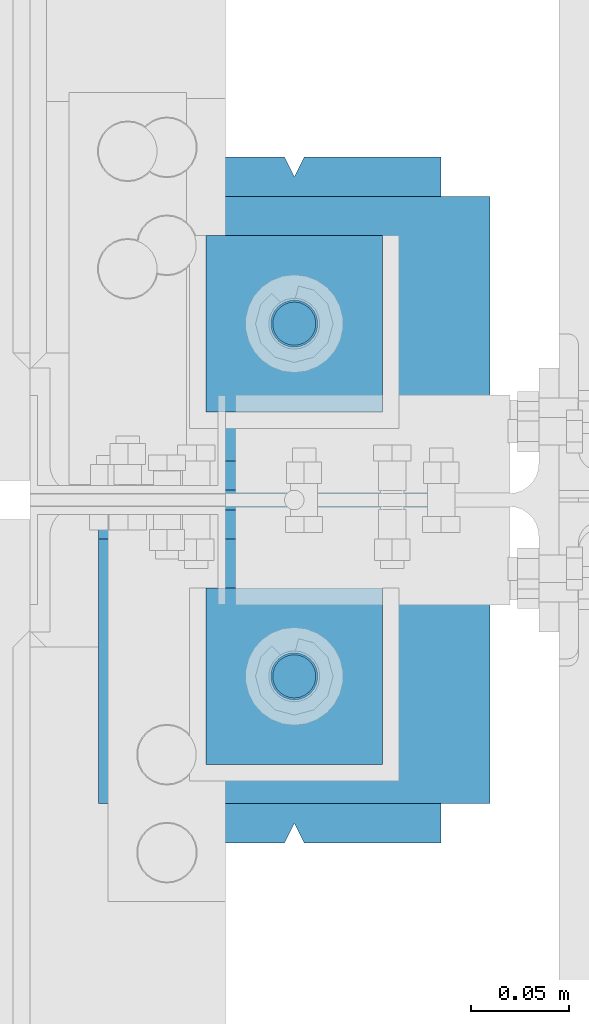
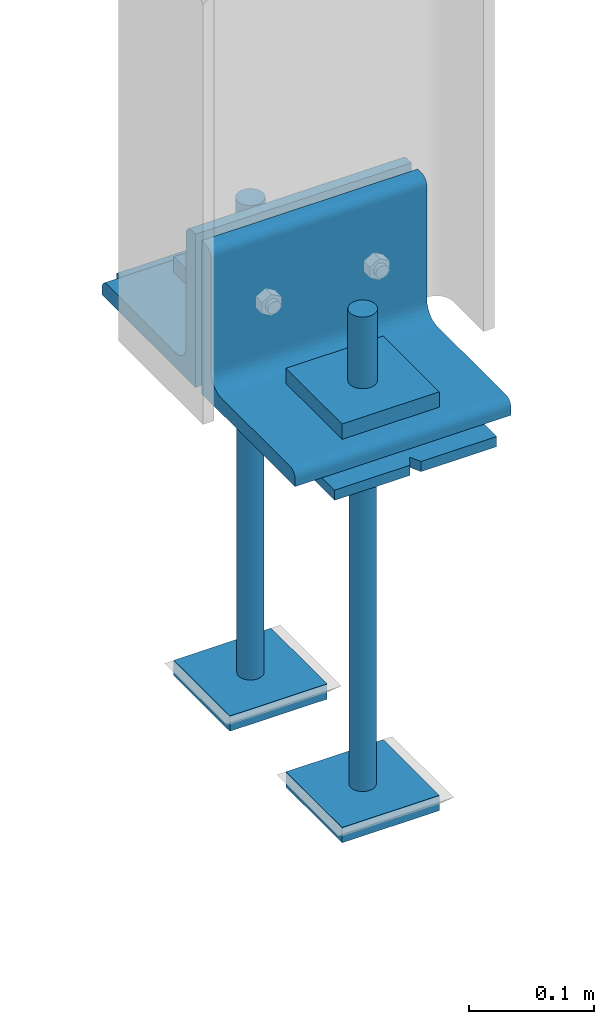
# One storey, part 65 of 496: 11 beams, 3 elements without a shape of their own.
"""IFC2X3 building model written with IfcOpenShell, lengths in millimetres."""

from ifc_helpers import new_model, si_unit, frame, origin_with_axes, origin_2d_with_axis, place, context, subcontext, project, spatial, polyline, rectangle, circle, l_section, outline, extrude, boolean, material, type_object, element, aggregate, save


model = new_model("IFC2X3")

# Units and contexts
model_context = context("Model", 3, precision=1e-05, world=origin_with_axes())
body_context = subcontext(model_context, "Body", "Model", "MODEL_VIEW")
ifc_project = project(units=[si_unit("LENGTHUNIT", "METRE", prefix="MILLI"), si_unit("AREAUNIT", "SQUARE_METRE"), si_unit("VOLUMEUNIT", "CUBIC_METRE"), si_unit("MASSUNIT", "GRAM", prefix="KILO"), si_unit("TIMEUNIT", "SECOND"), si_unit("PLANEANGLEUNIT", "RADIAN"), si_unit("SOLIDANGLEUNIT", "STERADIAN"), si_unit("THERMODYNAMICTEMPERATUREUNIT", "DEGREE_CELSIUS"), si_unit("LUMINOUSINTENSITYUNIT", "LUMEN")], contexts=[model_context])

# Site, building, storey
site_placement = place(None, origin_with_axes())
site = spatial("IfcSite", under=ifc_project, at=site_placement, CompositionType="ELEMENT")
building_placement = place(site_placement, origin_with_axes())
building = spatial("IfcBuilding", under=site, at=building_placement, Name="Undefined", CompositionType="ELEMENT")
storey_placement = place(building_placement, origin_with_axes())
storey = spatial("IfcBuildingStorey", under=building, at=storey_placement, Name="Undefined", CompositionType="ELEMENT", Elevation=0.0)

# Assembly, beams
assembly_1_placement = place(storey_placement, origin_with_axes())
assembly_1 = element("IfcElementAssembly", 1, at=assembly_1_placement, inside=storey, Name="PS24", AssemblyPlace="NOTDEFINED", PredefinedType="NOTDEFINED")
ifc_material = material(Name="Undefined/S235-E24")
beam_type_1 = type_object("IfcBeamType", PredefinedType="NOTDEFINED")
beam_1_placement = place(assembly_1_placement, frame((0.0, 3754.99715044471, -177.5), z_axis=(0.0, 0.0, 1.0), x_axis=(-1.0, 0.0, 0.0)))
beam_1 = element("IfcBeam", 2, at=beam_1_placement, type_object=beam_type_1, material=ifc_material, context=body_context, shape_type="SweptSolid", body=[
    extrude(outline(polyline([(0.0, 0.0), (90.0, 0.0), (90.0, 90.0), (0.0, 90.0), (0.0, 0.0)])), frame((0.0, 0.0, -7.5), z_axis=(0.0, 0.0, 1.0), x_axis=(1.0, 0.0, 0.0)), (0.0, 0.0, 1.0), 15.0),
])
beam_2_placement = place(assembly_1_placement, frame((0.0, 3934.99715044471, -177.5), z_axis=(0.0, 0.0, 1.0), x_axis=(-1.0, 0.0, 0.0)))
beam_2 = element("IfcBeam", 3, at=beam_2_placement, type_object=beam_type_1, material=ifc_material, context=body_context, shape_type="SweptSolid", body=[
    extrude(outline(polyline([(0.0, 0.0), (90.0, 0.0), (90.0, 90.0), (0.0, 90.0), (0.0, 0.0)])), frame((0.0, 0.0, -7.5), z_axis=(0.0, 0.0, 1.0), x_axis=(1.0, 0.0, 0.0)), (0.0, 0.0, 1.0), 15.0),
])
beam_3_placement = place(assembly_1_placement, frame((0.0, 3754.99715044471, -572.5), z_axis=(0.0, 0.0, 1.0), x_axis=(-1.0, 0.0, 0.0)))
beam_3 = element("IfcBeam", 4, at=beam_3_placement, type_object=beam_type_1, material=ifc_material, context=body_context, shape_type="SweptSolid", body=[
    extrude(outline(polyline([(0.0, 0.0), (90.0, 0.0), (90.0, 90.0), (0.0, 90.0), (0.0, 0.0)])), frame((0.0, 0.0, -7.5), z_axis=(0.0, 0.0, 1.0), x_axis=(1.0, 0.0, 0.0)), (0.0, 0.0, 1.0), 15.0),
])
beam_4_placement = place(assembly_1_placement, frame((0.0, 3934.99715044471, -572.5), z_axis=(0.0, 0.0, 1.0), x_axis=(-1.0, 0.0, 0.0)))
beam_4 = element("IfcBeam", 5, at=beam_4_placement, type_object=beam_type_1, material=ifc_material, context=body_context, shape_type="SweptSolid", body=[
    extrude(outline(polyline([(0.0, 0.0), (90.0, 0.0), (90.0, 90.0), (0.0, 90.0), (0.0, 0.0)])), frame((0.0, 0.0, -7.5), z_axis=(0.0, 0.0, 1.0), x_axis=(1.0, 0.0, 0.0)), (0.0, 0.0, 1.0), 15.0),
])
beam_type_2 = type_object("IfcBeamType", Name="D24", PredefinedType="NOTDEFINED")
beam_5_placement = place(assembly_1_placement, frame((-45.0, 3709.99715044471, -100.0), z_axis=(-1.0, 0.0, 0.0), x_axis=(0.0, 0.0, -1.0)))
beam_5 = element("IfcBeam", 6, at=beam_5_placement, type_object=beam_type_2, material=ifc_material, ObjectType="D24", context=body_context, shape_type="SweptSolid", body=[
    extrude(circle(Radius=12.0, at=origin_2d_with_axis()), frame((149.999995982835, 4.54747350886464e-12, 3.63797880709171e-12), z_axis=(-1.0, 0.0, 0.0), x_axis=(0.0, -1.0, 0.0)), (0.0, 0.0, 1.0), 150.0),
])
beam_6_placement = place(assembly_1_placement, frame((-45.0, 3889.99715044471, -100.0), z_axis=(-1.0, 0.0, 0.0), x_axis=(0.0, 0.0, -1.0)))
beam_6 = element("IfcBeam", 7, at=beam_6_placement, type_object=beam_type_2, material=ifc_material, ObjectType="D24", context=body_context, shape_type="SweptSolid", body=[
    extrude(circle(Radius=12.0, at=origin_2d_with_axis()), frame((149.999995982835, 4.54747350886464e-12, 3.63797880709171e-12), z_axis=(-1.0, 0.0, 0.0), x_axis=(0.0, -1.0, 0.0)), (0.0, 0.0, 1.0), 150.0),
])
beam_type_3 = type_object("IfcBeamType", Name="D22", PredefinedType="NOTDEFINED")
beam_7_placement = place(assembly_1_placement, frame((-45.0, 3709.99715044471, -250.0), z_axis=(-1.0, 0.0, 0.0), x_axis=(0.0, 0.0, -1.0)))
beam_7 = element("IfcBeam", 8, at=beam_7_placement, type_object=beam_type_3, material=ifc_material, ObjectType="D22", context=body_context, shape_type="SweptSolid", body=[
    extrude(circle(Radius=11.0, at=origin_2d_with_axis()), frame((350.0, 0.0, 0.0), z_axis=(-1.0, 0.0, 0.0), x_axis=(0.0, -1.0, 0.0)), (0.0, 0.0, 1.0), 350.0),
])
beam_8_placement = place(assembly_1_placement, frame((-45.0, 3889.99715044471, -250.0), z_axis=(-1.0, 0.0, 0.0), x_axis=(0.0, 0.0, -1.0)))
beam_8 = element("IfcBeam", 9, at=beam_8_placement, type_object=beam_type_3, material=ifc_material, ObjectType="D22", context=body_context, shape_type="SweptSolid", body=[
    extrude(circle(Radius=11.0, at=origin_2d_with_axis()), frame((350.0, 0.0, 0.0), z_axis=(-1.0, 0.0, 0.0), x_axis=(0.0, -1.0, 0.0)), (0.0, 0.0, 1.0), 350.0),
])
beam_type_4 = type_object("IfcBeamType", PredefinedType="NOTDEFINED")
beam_9_placement = place(assembly_1_placement, frame((-45.0, 3975.0, -205.0), z_axis=(1.0, 0.0, 0.0), x_axis=(0.0, -1.0, 0.0)))
beam_9 = element("IfcBeam", 10, at=beam_9_placement, type_object=beam_type_4, material=ifc_material, Name="PS24", context=body_context, shape_type="CSG", body=[
    boolean("DIFFERENCE", boolean("DIFFERENCE", boolean("DIFFERENCE", boolean("DIFFERENCE", extrude(rectangle(XDim=10.0, YDim=150.0, at=origin_2d_with_axis()), frame((350.0, 0.0, 0.0), z_axis=(-1.0, 0.0, 0.0), x_axis=(0.0, -1.0, 0.0)), (0.0, 0.0, 1.0), 350.0), extrude(outline(polyline([(0.0, 0.0), (11.1803398132297, 1.2732925824821e-11), (4.47213602066586, 8.94427204135718), (0.0, 0.0)])), frame((0.0, 7.5, -5.0), z_axis=(0.0, -1.0, 0.0), x_axis=(0.894427191199935, 0.0, 0.44721359509992)), (0.0, 0.0, 1.0), 15.0)), extrude(outline(polyline([(0.0, 0.0), (11.1803398132297, 1.2732925824821e-11), (4.47213602066586, 8.94427204135718), (0.0, 0.0)])), frame((180.0, 7.5, -75.0), z_axis=(0.0, -1.0, 0.0), x_axis=(-0.447213595099959, 0.0, 0.894427191199915)), (0.0, 0.0, 1.0), 15.0)), extrude(outline(polyline([(0.0, 0.0), (11.1803398132297, 1.2732925824821e-11), (6.70820379256475, 8.94427204134627), (0.0, 0.0)])), frame((340.0, 7.5, 0.0), z_axis=(0.0, -1.0, 0.0), x_axis=(0.894427191199935, 0.0, -0.44721359509992)), (0.0, 0.0, 1.0), 15.0)), extrude(outline(polyline([(0.0, 0.0), (11.1803398132297, 1.2732925824821e-11), (4.47213602066586, 8.94427204135718), (0.0, 0.0)])), frame((170.0, 7.5, 75.0), z_axis=(0.0, -1.0, 0.0), x_axis=(0.447213595099959, 0.0, -0.894427191199915)), (0.0, 0.0, 1.0), 15.0)),
])
aggregate(assembly_1, [beam_1, beam_2, beam_3, beam_4, beam_5, beam_7, beam_6, beam_8, beam_9])

# Assembly, beam
assembly_2_placement = place(storey_placement, origin_with_axes())
assembly_2 = element("IfcElementAssembly", 11, at=assembly_2_placement, inside=storey, AssemblyPlace="NOTDEFINED", PredefinedType="NOTDEFINED")
beam_type_5 = type_object("IfcBeamType", PredefinedType="NOTDEFINED")
beam_10_placement = place(assembly_2_placement, frame((55.0, 3880.0, -125.0), z_axis=(0.0, 0.0, 1.0), x_axis=(-1.0, 0.0, 0.0)))
beam_10 = element("IfcBeam", 12, at=beam_10_placement, type_object=beam_type_5, material=ifc_material, context=body_context, shape_type="SweptSolid", body=[
    extrude(l_section(Depth=150.0, Width=150.0, Thickness=15.0, FilletRadius=16.0, EdgeRadius=8.0, at=origin_2d_with_axis()), frame((200.0, 0.0, 0.0), z_axis=(-1.0, 0.0, 0.0), x_axis=(0.0, -1.0, 0.0)), (0.0, 0.0, 1.0), 200.0),
])
aggregate(assembly_2, [beam_10])

assembly_3_placement = place(storey_placement, origin_with_axes())
assembly_3 = element("IfcElementAssembly", 13, at=assembly_3_placement, inside=storey, AssemblyPlace="NOTDEFINED", PredefinedType="NOTDEFINED")
beam_11_placement = place(assembly_3_placement, frame((-145.0, 3720.0, -125.0), z_axis=(0.0, 0.0, 1.0), x_axis=(1.0, 0.0, 0.0)))
beam_11 = element("IfcBeam", 14, at=beam_11_placement, type_object=beam_type_5, material=ifc_material, context=body_context, shape_type="SweptSolid", body=[
    extrude(l_section(Depth=150.0, Width=150.0, Thickness=15.0, FilletRadius=16.0, EdgeRadius=8.0, at=origin_2d_with_axis()), frame((200.0, 0.0, 0.0), z_axis=(-1.0, 0.0, 0.0), x_axis=(0.0, -1.0, 0.0)), (0.0, 0.0, 1.0), 200.0),
])
aggregate(assembly_3, [beam_11])

save(model, "model.ifc")
